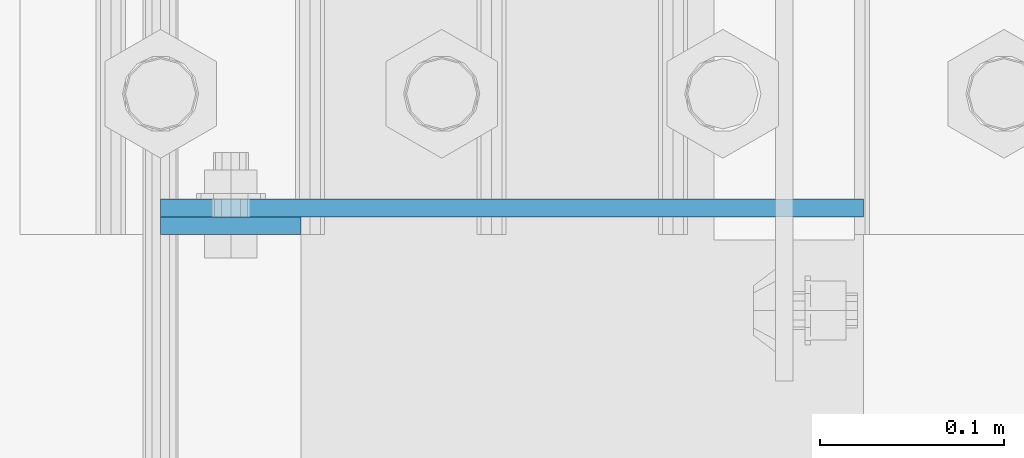
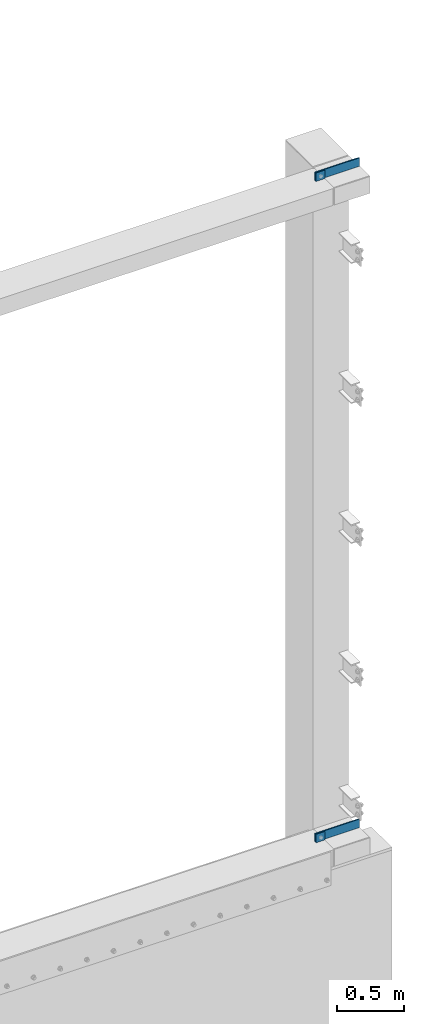
# One storey, part 1407 of 1876: 4 plates, 3 elements without a shape of their own.
"""IFC2X3 building model written with IfcOpenShell, lengths in millimetres."""

from ifc_helpers import new_model, si_unit, frame, origin_with_axes, place, context, subcontext, project, spatial, faceted_brep, material, type_object, element, aggregate, save


model = new_model("IFC2X3")

# Units and contexts
model_context = context("Model", 3, precision=1e-05, world=origin_with_axes())
body_context = subcontext(model_context, "Body", "Model", "MODEL_VIEW")
ifc_project = project(units=[si_unit("LENGTHUNIT", "METRE", prefix="MILLI"), si_unit("AREAUNIT", "SQUARE_METRE"), si_unit("VOLUMEUNIT", "CUBIC_METRE"), si_unit("MASSUNIT", "GRAM", prefix="KILO"), si_unit("TIMEUNIT", "SECOND"), si_unit("PLANEANGLEUNIT", "RADIAN"), si_unit("SOLIDANGLEUNIT", "STERADIAN"), si_unit("THERMODYNAMICTEMPERATUREUNIT", "DEGREE_CELSIUS"), si_unit("LUMINOUSINTENSITYUNIT", "LUMEN")], contexts=[model_context])

# Site, building, storey
site_placement = place(None, origin_with_axes())
site = spatial("IfcSite", under=ifc_project, at=site_placement, CompositionType="ELEMENT")
building_placement = place(site_placement, origin_with_axes())
building = spatial("IfcBuilding", under=site, at=building_placement, Name="Undefined", CompositionType="ELEMENT")
storey_placement = place(building_placement, origin_with_axes())
storey = spatial("IfcBuildingStorey", under=building, at=storey_placement, Name="Undefined", CompositionType="ELEMENT", Elevation=0.0)

# Assembly, plate
assembly_1_placement = place(storey_placement, origin_with_axes())
assembly_1 = element("IfcElementAssembly", 1, at=assembly_1_placement, inside=storey, Name="BEAM", AssemblyPlace="NOTDEFINED", PredefinedType="RIGID_FRAME")
ifc_material = material(Name="STEEL/A36")
plate_type = type_object("IfcPlateType", PredefinedType="NOTDEFINED")
plate_1_placement = place(assembly_1_placement, frame((7318.375, -25776.2375, 10667.9356518697), z_axis=(1.0, 0.0, 0.0), x_axis=(0.0, 0.0, 1.0)))
plate_1 = element("IfcPlate", 2, at=plate_1_placement, type_object=plate_type, material=ifc_material, Name="PLATE", context=body_context, shape_type="Brep", body=[
    faceted_brep([(0.0, -4.76249999999982, 0.0), (0.0643511861562729, -4.76249999999999, 76.1999969482422), (0.0643511861562729, 4.76249999999999, 76.1999969482422), (0.0, 4.76249999999982, 0.0), (76.2643508911133, -4.76249999999999, 76.1999969482422), (76.2643508911133, 4.76249999999999, 76.1999969482422), (76.2643508911133, -4.76249999999999, 0.0), (76.2643508911133, 4.76249999999999, 0.0)], [[[0, 1, 2, 3]], [[1, 4, 5, 2]], [[4, 6, 7, 5]], [[6, 0, 3, 7]], [[5, 7, 3, 2]], [[6, 4, 1, 0]]]),
])
aggregate(assembly_1, [plate_1])

assembly_2_placement = place(storey_placement, origin_with_axes())
assembly_2 = element("IfcElementAssembly", 3, at=assembly_2_placement, inside=storey, Name="COLUMN", AssemblyPlace="NOTDEFINED", PredefinedType="RIGID_FRAME")
plate_2_placement = place(assembly_2_placement, frame((7699.375, -25766.7125, 10744.2), z_axis=(-1.0, 0.0, 0.0), x_axis=(0.0, 0.0, -1.0)))
plate_2 = element("IfcPlate", 4, at=plate_2_placement, type_object=plate_type, material=ifc_material, Name="PLATE", context=body_context, shape_type="Brep", body=[
    faceted_brep([(0.0, -4.76249999999982, 0.0), (0.0, -4.76250000000073, 381.0), (0.0, 4.76250000000073, 381.0), (0.0, 4.76249999999982, 0.0), (76.1999969482422, -4.76250000000073, 381.0), (76.1999969482422, 4.76250000000073, 381.0), (76.1999969482422, -4.76250000000073, 0.0), (76.1999969482422, 4.76250000000073, 0.0)], [[[0, 1, 2, 3]], [[1, 4, 5, 2]], [[4, 6, 7, 5]], [[6, 0, 3, 7]], [[5, 7, 3, 2]], [[6, 4, 1, 0]]]),
])

assembly_3_placement = place(storey_placement, origin_with_axes())
assembly_3 = element("IfcElementAssembly", 5, at=assembly_3_placement, inside=storey, Name="BEAM", AssemblyPlace="NOTDEFINED", PredefinedType="RIGID_FRAME")
plate_3_placement = place(assembly_3_placement, frame((7318.375, -25776.2375, 4673.53565186968), z_axis=(1.0, 0.0, 0.0), x_axis=(0.0, 0.0, 1.0)))
plate_3 = element("IfcPlate", 6, at=plate_3_placement, type_object=plate_type, material=ifc_material, Name="PLATE", context=body_context, shape_type="Brep", body=[
    faceted_brep([(0.0, -4.76249999999982, 0.0), (0.0643511861562729, -4.76249999999999, 76.1999969482422), (0.0643511861562729, 4.76249999999999, 76.1999969482422), (0.0, 4.76249999999982, 0.0), (76.2643508911133, -4.76249999999999, 76.1999969482422), (76.2643508911133, 4.76249999999999, 76.1999969482422), (76.2643508911133, -4.76249999999999, 0.0), (76.2643508911133, 4.76249999999999, 0.0)], [[[0, 1, 2, 3]], [[1, 4, 5, 2]], [[4, 6, 7, 5]], [[6, 0, 3, 7]], [[5, 7, 3, 2]], [[6, 4, 1, 0]]]),
])
aggregate(assembly_3, [plate_3])

# Plate
plate_4_placement = place(assembly_2_placement, frame((7699.375, -25766.7125, 4749.8), z_axis=(-1.0, 0.0, 0.0), x_axis=(0.0, 0.0, -1.0)))
plate_4 = element("IfcPlate", 7, at=plate_4_placement, type_object=plate_type, material=ifc_material, Name="PLATE", context=body_context, shape_type="Brep", body=[
    faceted_brep([(0.0, -4.76249999999982, 0.0), (0.0, -4.76250000000073, 381.0), (0.0, 4.76250000000073, 381.0), (0.0, 4.76249999999982, 0.0), (76.1999969482422, -4.76250000000073, 381.0), (76.1999969482422, 4.76250000000073, 381.0), (76.1999969482422, -4.76250000000073, 0.0), (76.1999969482422, 4.76250000000073, 0.0)], [[[0, 1, 2, 3]], [[1, 4, 5, 2]], [[4, 6, 7, 5]], [[6, 0, 3, 7]], [[5, 7, 3, 2]], [[6, 4, 1, 0]]]),
])

aggregate(assembly_2, [plate_2, plate_4])

save(model, "model.ifc")
